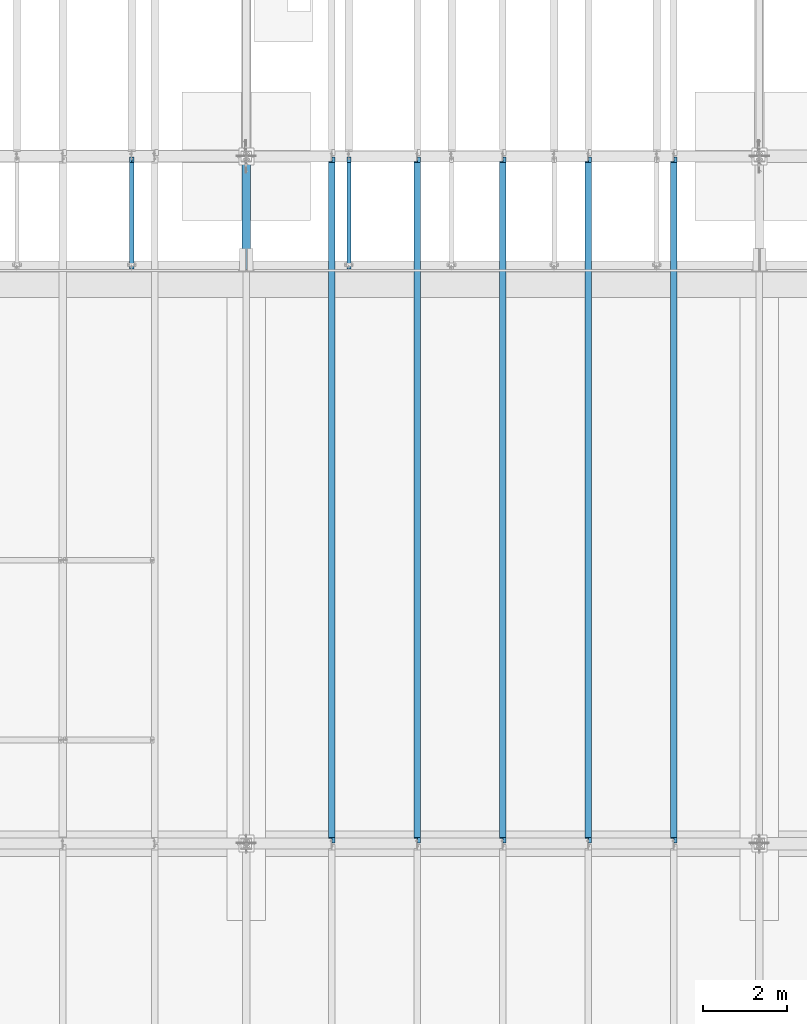
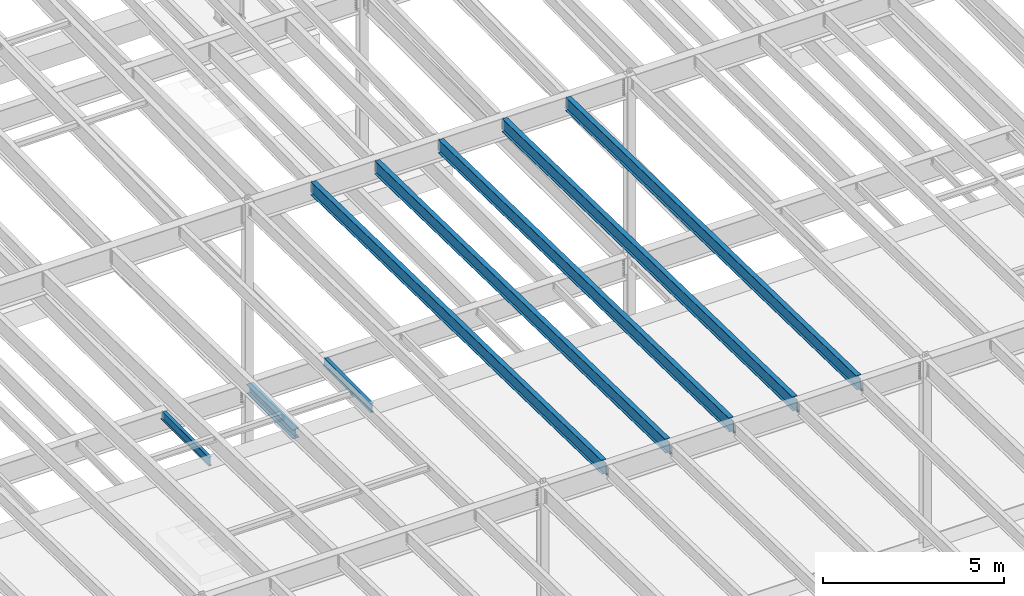
# One storey, part 1100 of 1763: 8 beams, 8 elements without a shape of their own.
"""IFC2X3 building model written with IfcOpenShell, lengths in millimetres."""

from ifc_helpers import new_model, si_unit, frame, origin_with_axes, place, context, subcontext, project, spatial, faceted_brep, material, type_object, element, aggregate, save


model = new_model("IFC2X3")

# Units and contexts
model_context = context("Model", 3, precision=1e-05, world=origin_with_axes())
body_context = subcontext(model_context, "Body", "Model", "MODEL_VIEW")
ifc_project = project(units=[si_unit("LENGTHUNIT", "METRE", prefix="MILLI"), si_unit("AREAUNIT", "SQUARE_METRE"), si_unit("VOLUMEUNIT", "CUBIC_METRE"), si_unit("MASSUNIT", "GRAM", prefix="KILO"), si_unit("TIMEUNIT", "SECOND"), si_unit("PLANEANGLEUNIT", "RADIAN"), si_unit("SOLIDANGLEUNIT", "STERADIAN"), si_unit("THERMODYNAMICTEMPERATUREUNIT", "DEGREE_CELSIUS"), si_unit("LUMINOUSINTENSITYUNIT", "LUMEN")], contexts=[model_context])

# Site, building, storey
site_placement = place(None, origin_with_axes())
site = spatial("IfcSite", under=ifc_project, at=site_placement, CompositionType="ELEMENT")
building_placement = place(site_placement, origin_with_axes())
building = spatial("IfcBuilding", under=site, at=building_placement, Name="Undefined", CompositionType="ELEMENT")
storey_placement = place(building_placement, origin_with_axes())
storey = spatial("IfcBuildingStorey", under=building, at=storey_placement, Name="Undefined", CompositionType="ELEMENT", Elevation=0.0)

# Assembly, beam
assembly_1_placement = place(storey_placement, origin_with_axes())
assembly_1 = element("IfcElementAssembly", 1, at=assembly_1_placement, inside=storey, Name="BEAM", AssemblyPlace="NOTDEFINED", PredefinedType="RIGID_FRAME")
ifc_material = material(Name="STEEL/A992")
beam_type_1 = type_object("IfcBeamType", Name="W12X16", PredefinedType="NOTDEFINED")
beam_1_placement = place(assembly_1_placement, frame((-59156.0372736983, 27279.6, 5041.9), z_axis=(0.0, 0.0, 1.0), x_axis=(0.0, 1.0, 0.0)))
beam_1 = element("IfcBeam", 2, at=beam_1_placement, type_object=beam_type_1, material=ifc_material, Name="BEAM", ObjectType="W12X16", context=body_context, shape_type="Brep", body=[
    faceted_brep([(63.5000000000036, -3.17499999999927, -146.05), (63.5000000000036, -50.7999999999993, -146.05), (2724.15000000001, -50.7999999999993, -146.05), (2724.15000000001, -3.17499999999927, -146.05), (63.5000000000036, -50.7999999999993, -152.4), (2724.15000000001, -50.7999999999993, -152.4), (63.5000000000036, 50.7999999999993, -152.4), (2724.15000000001, 50.7999999999993, -152.4), (63.5000000000036, 50.7999999999993, -146.05), (63.5000000000036, 3.17499999999927, -146.05), (2724.15000000001, 3.17499999999927, -146.05), (2724.15000000001, 50.7999999999993, -146.05), (2724.15000000001, 3.17499999999927, 120.390001678466), (2724.15000000001, -3.17499999999927, 120.390001678466), (63.5000000000036, -3.17499999999927, 146.05), (63.5000000000036, -50.7999999999993, 146.05), (63.5000000000036, -50.7999999999993, 152.4), (63.5000000000036, 50.7999999999993, 152.4), (63.5000000000036, 50.7999999999993, 146.05), (63.5000000000036, 3.17499999999927, 146.05), (2597.15000000001, 50.7999999999993, 146.05), (2597.15000000001, 3.17499999999927, 146.05), (2597.15000000001, 3.17499999999927, 133.090001487731), (2598.11672992259, 3.17499999999927, 128.229921969685), (2600.86974382307, 3.17499999999927, 124.109745501532), (2604.98992029122, 3.17499999999927, 121.356731601053), (2609.84999980927, 3.17499999999927, 120.390001678466), (2598.11672992259, -3.17499999999927, 128.229921969685), (2597.15000000001, -3.17499999999927, 133.090001487731), (2600.86974382307, -3.17499999999927, 124.109745501532), (2604.98992029122, -3.17499999999927, 121.356731601053), (2609.84999980927, -3.17499999999927, 120.390001678466), (2597.15000000001, -3.17499999999927, 146.05), (2597.15000000001, -50.7999999999993, 146.05), (2597.15000000001, -50.7999999999993, 152.4), (2597.15000000001, 50.7999999999993, 152.4)], [[[0, 1, 2, 3]], [[1, 4, 5, 2]], [[4, 6, 7, 5]], [[8, 9, 10, 11]], [[3, 2, 5, 7, 11, 10, 12, 13]], [[6, 8, 11, 7]], [[4, 1, 0, 14, 15, 16, 17, 18, 19, 9, 8, 6]], [[19, 18, 20, 21]], [[10, 9, 19, 21, 22, 23, 24, 25, 26, 12]], [[27, 23, 22, 28]], [[29, 24, 23, 27]], [[30, 25, 24, 29]], [[31, 26, 25, 30]], [[13, 12, 26, 31]], [[30, 29, 27, 28, 32, 14, 0, 3, 13, 31]], [[15, 14, 32, 33]], [[16, 15, 33, 34]], [[17, 16, 34, 35]], [[18, 17, 35, 20]], [[34, 33, 32, 28, 22, 21, 20, 35]]]),
])
aggregate(assembly_1, [beam_1])

assembly_2_placement = place(storey_placement, origin_with_axes())
assembly_2 = element("IfcElementAssembly", 3, at=assembly_2_placement, inside=storey, Name="BEAM", AssemblyPlace="NOTDEFINED", PredefinedType="RIGID_FRAME")
beam_2_placement = place(assembly_2_placement, frame((-64318.5872736984, 27279.6, 5041.9), z_axis=(0.0, 0.0, 1.0), x_axis=(0.0, 1.0, 0.0)))
beam_2 = element("IfcBeam", 4, at=beam_2_placement, type_object=beam_type_1, material=ifc_material, Name="BEAM", ObjectType="W12X16", context=body_context, shape_type="Brep", body=[
    faceted_brep([(63.5000000000036, -3.17499999999927, -146.05), (63.5000000000036, -50.7999999999993, -146.05), (2724.15000000001, -50.7999999999993, -146.05), (2724.15000000001, -3.17499999999927, -146.05), (63.5000000000036, -50.7999999999993, -152.4), (2724.15000000001, -50.7999999999993, -152.4), (63.5000000000036, 50.7999999999993, -152.4), (2724.15000000001, 50.7999999999993, -152.4), (63.5000000000036, 50.7999999999993, -146.05), (63.5000000000036, 3.17499999999927, -146.05), (2724.15000000001, 3.17499999999927, -146.05), (2724.15000000001, 50.7999999999993, -146.05), (2724.15000000001, 3.17499999999927, 120.390001678466), (2724.15000000001, -3.17499999999927, 120.390001678466), (63.5000000000036, -3.17499999999927, 146.05), (63.5000000000036, -50.7999999999993, 146.05), (63.5000000000036, -50.7999999999993, 152.4), (63.5000000000036, 50.7999999999993, 152.4), (63.5000000000036, 50.7999999999993, 146.05), (63.5000000000036, 3.17499999999927, 146.05), (2597.15000000001, 50.7999999999993, 146.05), (2597.15000000001, 3.17499999999927, 146.05), (2597.15000000001, 3.17499999999927, 133.090001487731), (2598.11672992259, 3.17499999999927, 128.229921969685), (2600.86974382307, 3.17499999999927, 124.109745501532), (2604.98992029122, 3.17499999999927, 121.356731601053), (2609.84999980927, 3.17499999999927, 120.390001678466), (2598.11672992259, -3.17499999999927, 128.229921969685), (2597.15000000001, -3.17499999999927, 133.090001487731), (2600.86974382307, -3.17499999999927, 124.109745501532), (2604.98992029122, -3.17499999999927, 121.356731601053), (2609.84999980927, -3.17499999999927, 120.390001678466), (2597.15000000001, -3.17499999999927, 146.05), (2597.15000000001, -50.7999999999993, 146.05), (2597.15000000001, -50.7999999999993, 152.4), (2597.15000000001, 50.7999999999993, 152.4)], [[[0, 1, 2, 3]], [[1, 4, 5, 2]], [[4, 6, 7, 5]], [[8, 9, 10, 11]], [[3, 2, 5, 7, 11, 10, 12, 13]], [[6, 8, 11, 7]], [[4, 1, 0, 14, 15, 16, 17, 18, 19, 9, 8, 6]], [[19, 18, 20, 21]], [[10, 9, 19, 21, 22, 23, 24, 25, 26, 12]], [[27, 23, 22, 28]], [[29, 24, 23, 27]], [[30, 25, 24, 29]], [[31, 26, 25, 30]], [[13, 12, 26, 31]], [[30, 29, 27, 28, 32, 14, 0, 3, 13, 31]], [[15, 14, 32, 33]], [[16, 15, 33, 34]], [[17, 16, 34, 35]], [[18, 17, 35, 20]], [[34, 33, 32, 28, 22, 21, 20, 35]]]),
])
aggregate(assembly_2, [beam_2])

assembly_3_placement = place(storey_placement, origin_with_axes())
assembly_3 = element("IfcElementAssembly", 5, at=assembly_3_placement, inside=storey, Name="BEAM", AssemblyPlace="NOTDEFINED", PredefinedType="RIGID_FRAME")
beam_type_2 = type_object("IfcBeamType", Name="W18X40", PredefinedType="NOTDEFINED")
beam_3_placement = place(assembly_3_placement, frame((-51434.4372736983, 13685.8551306872, 11404.7768219843), z_axis=(0.0, 0.0209013539966291, 0.999781542838788), x_axis=(0.0, 0.999781542776098, -0.0209013569953182)))
beam_3 = element("IfcBeam", 6, at=beam_3_placement, type_object=beam_type_2, material=ifc_material, Name="BEAM", ObjectType="W18X40", context=body_context, shape_type="Brep", body=[
    faceted_brep([(131.750078376836, 4.26866853544198, -214.312499999891), (131.750078376825, 4.26882839153404, -227.012499999888), (28.545974688046, 4.26881528460945, -227.012499999948), (28.2804694526694, 4.26865539480787, -214.312499999951), (131.750069241622, 76.1999999999971, -214.312499999891), (131.750069241631, 76.1999999999971, -227.012499999888), (150.800068605527, -3.96875, 195.002501487816), (150.800068605527, 3.96875, 195.002501487816), (149.833338682944, 3.96875, 190.142421969771), (149.833338682944, -3.96875, 190.142421969771), (147.080324782468, 3.96875, 186.022245501617), (147.080324782468, -3.96875, 186.022245501617), (142.96014831432, 3.96875, 183.26923160114), (142.96014831432, -3.96875, 183.26923160114), (138.100068796275, 3.96875, 182.30250167855), (138.100068796275, -3.96875, 182.30250167855), (19.9888663522943, 3.96875, 182.30250167848), (19.9888663522943, -3.96875, 182.30250167848), (28.2804694526694, -3.96875, -214.312499999951), (16325.9408112312, -3.96875, -214.312499990356), (16317.649208128, -3.96875, 182.302501822607), (16200.8104101848, -3.96875, 182.302501822538), (16195.9503306668, -3.96875, 183.269231745124), (16191.8301541986, -3.96875, 186.022245645598), (16189.0771402981, -3.96875, 190.142422113749), (16188.1104103755, -3.96875, 195.00250163179), (16188.1104103755, -3.96875, 214.312500009501), (150.800068605517, -3.96875, 214.312500000058), (28.2804694526694, -76.1999999999971, -214.312499999951), (16325.9408112312, -76.1999999999971, -214.312499990356), (28.545974688046, -76.1999999999971, -227.012499999948), (16326.2063164666, -76.1999999999971, -227.012499990355), (16224.3506317604, 76.1999999999971, -215.844166655699), (16224.3506317604, 4.71875000000728, -215.844166655699), (16226.2104072906, 4.71875000000728, -215.805286329723), (16226.2104011431, 76.1999999999971, -215.805286458244), (16224.3186108535, 4.71875000000728, -214.312499990414), (16224.3186108535, 76.1999999999971, -214.312499990414), (16226.2104072906, 4.71875000000728, -214.312499990414), (16226.2104073293, 4.26882837418816, -214.312499990414), (16226.2104073293, 4.26866852503008, -227.012499990411), (16226.2104011431, 76.1999999999971, -227.012499990411), (16326.2063164666, 4.26867712486273, -227.012499990355), (16325.9408112312, 4.26883695115976, -214.312499990356), (16325.9408112312, 3.96875, -214.312499990356), (16317.649208128, 3.96875, 182.302501822607), (16200.8104101848, 3.96875, 182.302501822538), (16195.9503306668, 3.96875, 183.269231745124), (16191.8301541986, 3.96875, 186.022245645598), (16189.0771402981, 3.96875, 190.142422113749), (16188.1104103755, 3.96875, 195.00250163179), (16188.1104103755, -76.1999999999971, 227.012500009499), (16188.1104103755, -76.1999999999971, 214.312500009501), (16188.1104103755, 3.96875, 214.312500009501), (16188.1104103755, 76.1999999999971, 214.312500009501), (16188.1104103755, 76.1999999999971, 227.012500009499), (150.800068605517, 3.96875, 214.312500000058), (150.800068605517, 76.1999999999971, 214.312500000058), (150.800068605509, 76.1999999999971, 227.012500000057), (150.800068605509, -76.1999999999971, 227.012500000057), (150.800068605517, -76.1999999999971, 214.312500000058), (28.2804694526694, 3.96875, -214.312499999951)], [[[0, 1, 2, 3]], [[4, 5, 1, 0]], [[6, 7, 8, 9]], [[9, 8, 10, 11]], [[11, 10, 12, 13]], [[13, 12, 14, 15]], [[15, 14, 16, 17]], [[9, 11, 13, 15, 17, 18, 19, 20, 21, 22, 23, 24, 25, 26, 27, 6]], [[18, 28, 29, 19]], [[28, 30, 31, 29]], [[32, 33, 34, 35]], [[36, 33, 32, 37]], [[33, 36, 38, 34]], [[39, 40, 41, 35, 34, 38]], [[42, 40, 39, 43]], [[44, 45, 20, 19, 29, 31, 42, 43]], [[20, 45, 46, 21]], [[21, 46, 47, 22]], [[22, 47, 48, 23]], [[23, 48, 49, 24]], [[24, 49, 50, 25]], [[51, 52, 26, 25, 50, 53, 54, 55]], [[54, 53, 56, 57]], [[55, 54, 57, 58]], [[51, 55, 58, 59]], [[52, 51, 59, 60]], [[26, 52, 60, 27]], [[59, 58, 57, 56, 7, 6, 27, 60]], [[53, 50, 49, 48, 47, 46, 45, 44, 61, 16, 14, 12, 10, 8, 7, 56]], [[30, 28, 18, 17, 16, 61, 3, 2]], [[41, 40, 42, 31, 30, 2, 1, 5]], [[37, 32, 35, 41, 5, 4]], [[61, 44, 43, 39, 38, 36, 37, 4, 0, 3]]]),
])
aggregate(assembly_3, [beam_3])

assembly_4_placement = place(storey_placement, origin_with_axes())
assembly_4 = element("IfcElementAssembly", 7, at=assembly_4_placement, inside=storey, Name="BEAM", AssemblyPlace="NOTDEFINED", PredefinedType="RIGID_FRAME")
beam_4_placement = place(assembly_4_placement, frame((-53466.4372736983, 13685.8551306872, 11404.7768219843), z_axis=(0.0, 0.0209013539966291, 0.999781542838788), x_axis=(0.0, 0.999781542776098, -0.0209013569953182)))
beam_4 = element("IfcBeam", 8, at=beam_4_placement, type_object=beam_type_2, material=ifc_material, Name="BEAM", ObjectType="W18X40", context=body_context, shape_type="Brep", body=[
    faceted_brep([(131.750078376836, 4.26866853544198, -214.312499999891), (131.750078376825, 4.26882839153404, -227.012499999888), (28.545974688046, 4.26881528460945, -227.012499999948), (28.2804694526694, 4.26865539480787, -214.312499999951), (131.750069241622, 76.1999999999971, -214.312499999891), (131.750069241631, 76.1999999999971, -227.012499999888), (150.800068605527, -3.96875, 195.002501487816), (150.800068605527, 3.96875, 195.002501487816), (149.833338682944, 3.96875, 190.142421969771), (149.833338682944, -3.96875, 190.142421969771), (147.080324782468, 3.96875, 186.022245501617), (147.080324782468, -3.96875, 186.022245501617), (142.96014831432, 3.96875, 183.26923160114), (142.96014831432, -3.96875, 183.26923160114), (138.100068796275, 3.96875, 182.30250167855), (138.100068796275, -3.96875, 182.30250167855), (19.9888663522943, 3.96875, 182.30250167848), (19.9888663522943, -3.96875, 182.30250167848), (28.2804694526694, -3.96875, -214.312499999951), (16325.9408112312, -3.96875, -214.312499990356), (16317.649208128, -3.96875, 182.302501822607), (16200.8104101848, -3.96875, 182.302501822538), (16195.9503306668, -3.96875, 183.269231745124), (16191.8301541986, -3.96875, 186.022245645598), (16189.0771402981, -3.96875, 190.142422113749), (16188.1104103755, -3.96875, 195.00250163179), (16188.1104103755, -3.96875, 214.312500009501), (150.800068605517, -3.96875, 214.312500000058), (28.2804694526694, -76.1999999999971, -214.312499999951), (16325.9408112312, -76.1999999999971, -214.312499990356), (28.545974688046, -76.1999999999971, -227.012499999948), (16326.2063164666, -76.1999999999971, -227.012499990355), (16224.3506317604, 76.1999999999971, -215.844166655699), (16224.3506317604, 4.71875000000728, -215.844166655699), (16226.2104072906, 4.71875000000728, -215.805286329723), (16226.2104011431, 76.1999999999971, -215.805286458244), (16224.3186108535, 4.71875000000728, -214.312499990414), (16224.3186108535, 76.1999999999971, -214.312499990414), (16226.2104072906, 4.71875000000728, -214.312499990414), (16226.2104073293, 4.26882837418816, -214.312499990414), (16226.2104073293, 4.26866852503008, -227.012499990411), (16226.2104011431, 76.1999999999971, -227.012499990411), (16326.2063164666, 4.26867712486273, -227.012499990355), (16325.9408112312, 4.26883695115976, -214.312499990356), (16325.9408112312, 3.96875, -214.312499990356), (16317.649208128, 3.96875, 182.302501822607), (16200.8104101848, 3.96875, 182.302501822538), (16195.9503306668, 3.96875, 183.269231745124), (16191.8301541986, 3.96875, 186.022245645598), (16189.0771402981, 3.96875, 190.142422113749), (16188.1104103755, 3.96875, 195.00250163179), (16188.1104103755, -76.1999999999971, 227.012500009499), (16188.1104103755, -76.1999999999971, 214.312500009501), (16188.1104103755, 3.96875, 214.312500009501), (16188.1104103755, 76.1999999999971, 214.312500009501), (16188.1104103755, 76.1999999999971, 227.012500009499), (150.800068605517, 3.96875, 214.312500000058), (150.800068605517, 76.1999999999971, 214.312500000058), (150.800068605509, 76.1999999999971, 227.012500000057), (150.800068605509, -76.1999999999971, 227.012500000057), (150.800068605517, -76.1999999999971, 214.312500000058), (28.2804694526694, 3.96875, -214.312499999951)], [[[0, 1, 2, 3]], [[4, 5, 1, 0]], [[6, 7, 8, 9]], [[9, 8, 10, 11]], [[11, 10, 12, 13]], [[13, 12, 14, 15]], [[15, 14, 16, 17]], [[9, 11, 13, 15, 17, 18, 19, 20, 21, 22, 23, 24, 25, 26, 27, 6]], [[18, 28, 29, 19]], [[28, 30, 31, 29]], [[32, 33, 34, 35]], [[36, 33, 32, 37]], [[33, 36, 38, 34]], [[39, 40, 41, 35, 34, 38]], [[42, 40, 39, 43]], [[44, 45, 20, 19, 29, 31, 42, 43]], [[20, 45, 46, 21]], [[21, 46, 47, 22]], [[22, 47, 48, 23]], [[23, 48, 49, 24]], [[24, 49, 50, 25]], [[51, 52, 26, 25, 50, 53, 54, 55]], [[54, 53, 56, 57]], [[55, 54, 57, 58]], [[51, 55, 58, 59]], [[52, 51, 59, 60]], [[26, 52, 60, 27]], [[59, 58, 57, 56, 7, 6, 27, 60]], [[53, 50, 49, 48, 47, 46, 45, 44, 61, 16, 14, 12, 10, 8, 7, 56]], [[30, 28, 18, 17, 16, 61, 3, 2]], [[41, 40, 42, 31, 30, 2, 1, 5]], [[37, 32, 35, 41, 5, 4]], [[61, 44, 43, 39, 38, 36, 37, 4, 0, 3]]]),
])
aggregate(assembly_4, [beam_4])

assembly_5_placement = place(storey_placement, origin_with_axes())
assembly_5 = element("IfcElementAssembly", 9, at=assembly_5_placement, inside=storey, Name="BEAM", AssemblyPlace="NOTDEFINED", PredefinedType="RIGID_FRAME")
beam_5_placement = place(assembly_5_placement, frame((-55498.4372736983, 13685.8551306872, 11404.7768219843), z_axis=(0.0, 0.0209013539966291, 0.999781542838788), x_axis=(0.0, 0.999781542776098, -0.0209013569953182)))
beam_5 = element("IfcBeam", 10, at=beam_5_placement, type_object=beam_type_2, material=ifc_material, Name="BEAM", ObjectType="W18X40", context=body_context, shape_type="Brep", body=[
    faceted_brep([(131.750078376836, 4.26866853544198, -214.312499999891), (131.750078376825, 4.26882839153404, -227.012499999888), (28.545974688046, 4.26881528460945, -227.012499999948), (28.2804694526694, 4.26865539480787, -214.312499999951), (131.750069241622, 76.1999999999971, -214.312499999891), (131.750069241631, 76.1999999999971, -227.012499999888), (150.800068605527, -3.96875, 195.002501487816), (150.800068605527, 3.96875, 195.002501487816), (149.833338682944, 3.96875, 190.142421969771), (149.833338682944, -3.96875, 190.142421969771), (147.080324782468, 3.96875, 186.022245501617), (147.080324782468, -3.96875, 186.022245501617), (142.96014831432, 3.96875, 183.26923160114), (142.96014831432, -3.96875, 183.26923160114), (138.100068796275, 3.96875, 182.30250167855), (138.100068796275, -3.96875, 182.30250167855), (19.9888663522943, 3.96875, 182.30250167848), (19.9888663522943, -3.96875, 182.30250167848), (28.2804694526694, -3.96875, -214.312499999951), (16325.9408112312, -3.96875, -214.312499990356), (16317.649208128, -3.96875, 182.302501822607), (16200.8104101848, -3.96875, 182.302501822538), (16195.9503306668, -3.96875, 183.269231745124), (16191.8301541986, -3.96875, 186.022245645598), (16189.0771402981, -3.96875, 190.142422113749), (16188.1104103755, -3.96875, 195.00250163179), (16188.1104103755, -3.96875, 214.312500009501), (150.800068605517, -3.96875, 214.312500000058), (28.2804694526694, -76.1999999999971, -214.312499999951), (16325.9408112312, -76.1999999999971, -214.312499990356), (28.545974688046, -76.1999999999971, -227.012499999948), (16326.2063164666, -76.1999999999971, -227.012499990355), (16224.3506317604, 76.1999999999971, -215.844166655699), (16224.3506317604, 4.71875000000728, -215.844166655699), (16226.2104072906, 4.71875000000728, -215.805286329723), (16226.2104011431, 76.1999999999971, -215.805286458244), (16224.3186108535, 4.71875000000728, -214.312499990414), (16224.3186108535, 76.1999999999971, -214.312499990414), (16226.2104072906, 4.71875000000728, -214.312499990414), (16226.2104073293, 4.26882837418816, -214.312499990414), (16226.2104073293, 4.26866852503008, -227.012499990411), (16226.2104011431, 76.1999999999971, -227.012499990411), (16326.2063164666, 4.26867712486273, -227.012499990355), (16325.9408112312, 4.26883695115976, -214.312499990356), (16325.9408112312, 3.96875, -214.312499990356), (16317.649208128, 3.96875, 182.302501822607), (16200.8104101848, 3.96875, 182.302501822538), (16195.9503306668, 3.96875, 183.269231745124), (16191.8301541986, 3.96875, 186.022245645598), (16189.0771402981, 3.96875, 190.142422113749), (16188.1104103755, 3.96875, 195.00250163179), (16188.1104103755, -76.1999999999971, 227.012500009499), (16188.1104103755, -76.1999999999971, 214.312500009501), (16188.1104103755, 3.96875, 214.312500009501), (16188.1104103755, 76.1999999999971, 214.312500009501), (16188.1104103755, 76.1999999999971, 227.012500009499), (150.800068605517, 3.96875, 214.312500000058), (150.800068605517, 76.1999999999971, 214.312500000058), (150.800068605509, 76.1999999999971, 227.012500000057), (150.800068605509, -76.1999999999971, 227.012500000057), (150.800068605517, -76.1999999999971, 214.312500000058), (28.2804694526694, 3.96875, -214.312499999951)], [[[0, 1, 2, 3]], [[4, 5, 1, 0]], [[6, 7, 8, 9]], [[9, 8, 10, 11]], [[11, 10, 12, 13]], [[13, 12, 14, 15]], [[15, 14, 16, 17]], [[9, 11, 13, 15, 17, 18, 19, 20, 21, 22, 23, 24, 25, 26, 27, 6]], [[18, 28, 29, 19]], [[28, 30, 31, 29]], [[32, 33, 34, 35]], [[36, 33, 32, 37]], [[33, 36, 38, 34]], [[39, 40, 41, 35, 34, 38]], [[42, 40, 39, 43]], [[44, 45, 20, 19, 29, 31, 42, 43]], [[20, 45, 46, 21]], [[21, 46, 47, 22]], [[22, 47, 48, 23]], [[23, 48, 49, 24]], [[24, 49, 50, 25]], [[51, 52, 26, 25, 50, 53, 54, 55]], [[54, 53, 56, 57]], [[55, 54, 57, 58]], [[51, 55, 58, 59]], [[52, 51, 59, 60]], [[26, 52, 60, 27]], [[59, 58, 57, 56, 7, 6, 27, 60]], [[53, 50, 49, 48, 47, 46, 45, 44, 61, 16, 14, 12, 10, 8, 7, 56]], [[30, 28, 18, 17, 16, 61, 3, 2]], [[41, 40, 42, 31, 30, 2, 1, 5]], [[37, 32, 35, 41, 5, 4]], [[61, 44, 43, 39, 38, 36, 37, 4, 0, 3]]]),
])
aggregate(assembly_5, [beam_5])

assembly_6_placement = place(storey_placement, origin_with_axes())
assembly_6 = element("IfcElementAssembly", 11, at=assembly_6_placement, inside=storey, Name="BEAM", AssemblyPlace="NOTDEFINED", PredefinedType="RIGID_FRAME")
beam_6_placement = place(assembly_6_placement, frame((-57530.4372736983, 13685.8551306872, 11404.7768219843), z_axis=(0.0, 0.0209013539966291, 0.999781542838788), x_axis=(0.0, 0.999781542776098, -0.0209013569953182)))
beam_6 = element("IfcBeam", 12, at=beam_6_placement, type_object=beam_type_2, material=ifc_material, Name="BEAM", ObjectType="W18X40", context=body_context, shape_type="Brep", body=[
    faceted_brep([(131.750078376836, 4.26866853544198, -214.312499999891), (131.750078376825, 4.26882839153404, -227.012499999888), (28.545974688046, 4.26881528460945, -227.012499999948), (28.2804694526694, 4.26865539480787, -214.312499999951), (131.750069241622, 76.1999999999971, -214.312499999891), (131.750069241631, 76.1999999999971, -227.012499999888), (150.800068605527, -3.96875, 195.002501487816), (150.800068605527, 3.96875, 195.002501487816), (149.833338682944, 3.96875, 190.142421969771), (149.833338682944, -3.96875, 190.142421969771), (147.080324782468, 3.96875, 186.022245501617), (147.080324782468, -3.96875, 186.022245501617), (142.96014831432, 3.96875, 183.26923160114), (142.96014831432, -3.96875, 183.26923160114), (138.100068796275, 3.96875, 182.30250167855), (138.100068796275, -3.96875, 182.30250167855), (19.9888663522943, 3.96875, 182.30250167848), (19.9888663522943, -3.96875, 182.30250167848), (28.2804694526694, -3.96875, -214.312499999951), (16325.9408112312, -3.96875, -214.312499990356), (16317.649208128, -3.96875, 182.302501822607), (16200.8104101848, -3.96875, 182.302501822538), (16195.9503306668, -3.96875, 183.269231745124), (16191.8301541986, -3.96875, 186.022245645598), (16189.0771402981, -3.96875, 190.142422113749), (16188.1104103755, -3.96875, 195.00250163179), (16188.1104103755, -3.96875, 214.312500009501), (150.800068605517, -3.96875, 214.312500000058), (28.2804694526694, -76.1999999999971, -214.312499999951), (16325.9408112312, -76.1999999999971, -214.312499990356), (28.545974688046, -76.1999999999971, -227.012499999948), (16326.2063164666, -76.1999999999971, -227.012499990355), (16224.3506317604, 76.1999999999971, -215.844166655699), (16224.3506317604, 4.71875000000728, -215.844166655699), (16226.2104072906, 4.71875000000728, -215.805286329723), (16226.2104011431, 76.1999999999971, -215.805286458244), (16224.3186108535, 4.71875000000728, -214.312499990414), (16224.3186108535, 76.1999999999971, -214.312499990414), (16226.2104072906, 4.71875000000728, -214.312499990414), (16226.2104073293, 4.26882837418816, -214.312499990414), (16226.2104073293, 4.26866852503008, -227.012499990411), (16226.2104011431, 76.1999999999971, -227.012499990411), (16326.2063164666, 4.26867712486273, -227.012499990355), (16325.9408112312, 4.26883695115976, -214.312499990356), (16325.9408112312, 3.96875, -214.312499990356), (16317.649208128, 3.96875, 182.302501822607), (16200.8104101848, 3.96875, 182.302501822538), (16195.9503306668, 3.96875, 183.269231745124), (16191.8301541986, 3.96875, 186.022245645598), (16189.0771402981, 3.96875, 190.142422113749), (16188.1104103755, 3.96875, 195.00250163179), (16188.1104103755, -76.1999999999971, 227.012500009499), (16188.1104103755, -76.1999999999971, 214.312500009501), (16188.1104103755, 3.96875, 214.312500009501), (16188.1104103755, 76.1999999999971, 214.312500009501), (16188.1104103755, 76.1999999999971, 227.012500009499), (150.800068605517, 3.96875, 214.312500000058), (150.800068605517, 76.1999999999971, 214.312500000058), (150.800068605509, 76.1999999999971, 227.012500000057), (150.800068605509, -76.1999999999971, 227.012500000057), (150.800068605517, -76.1999999999971, 214.312500000058), (28.2804694526694, 3.96875, -214.312499999951)], [[[0, 1, 2, 3]], [[4, 5, 1, 0]], [[6, 7, 8, 9]], [[9, 8, 10, 11]], [[11, 10, 12, 13]], [[13, 12, 14, 15]], [[15, 14, 16, 17]], [[9, 11, 13, 15, 17, 18, 19, 20, 21, 22, 23, 24, 25, 26, 27, 6]], [[18, 28, 29, 19]], [[28, 30, 31, 29]], [[32, 33, 34, 35]], [[36, 33, 32, 37]], [[33, 36, 38, 34]], [[39, 40, 41, 35, 34, 38]], [[42, 40, 39, 43]], [[44, 45, 20, 19, 29, 31, 42, 43]], [[20, 45, 46, 21]], [[21, 46, 47, 22]], [[22, 47, 48, 23]], [[23, 48, 49, 24]], [[24, 49, 50, 25]], [[51, 52, 26, 25, 50, 53, 54, 55]], [[54, 53, 56, 57]], [[55, 54, 57, 58]], [[51, 55, 58, 59]], [[52, 51, 59, 60]], [[26, 52, 60, 27]], [[59, 58, 57, 56, 7, 6, 27, 60]], [[53, 50, 49, 48, 47, 46, 45, 44, 61, 16, 14, 12, 10, 8, 7, 56]], [[30, 28, 18, 17, 16, 61, 3, 2]], [[41, 40, 42, 31, 30, 2, 1, 5]], [[37, 32, 35, 41, 5, 4]], [[61, 44, 43, 39, 38, 36, 37, 4, 0, 3]]]),
])
aggregate(assembly_6, [beam_6])

assembly_7_placement = place(storey_placement, origin_with_axes())
assembly_7 = element("IfcElementAssembly", 13, at=assembly_7_placement, inside=storey, Name="BEAM", AssemblyPlace="NOTDEFINED", PredefinedType="RIGID_FRAME")
beam_7_placement = place(assembly_7_placement, frame((-59562.4372736983, 13685.8551306872, 11404.7768219843), z_axis=(0.0, 0.0209013539966291, 0.999781542838788), x_axis=(0.0, 0.999781542776098, -0.0209013569953182)))
beam_7 = element("IfcBeam", 14, at=beam_7_placement, type_object=beam_type_2, material=ifc_material, Name="BEAM", ObjectType="W18X40", context=body_context, shape_type="Brep", body=[
    faceted_brep([(131.750078376836, 4.26866853544198, -214.312499999891), (131.750078376825, 4.26882839153404, -227.012499999888), (28.545974688046, 4.26881528460945, -227.012499999948), (28.2804694526694, 4.26865539480787, -214.312499999951), (131.750069241622, 76.1999999999971, -214.312499999891), (131.750069241631, 76.1999999999971, -227.012499999888), (150.800068605527, -3.96875, 195.002501487816), (150.800068605527, 3.96875, 195.002501487816), (149.833338682944, 3.96875, 190.142421969771), (149.833338682944, -3.96875, 190.142421969771), (147.080324782468, 3.96875, 186.022245501617), (147.080324782468, -3.96875, 186.022245501617), (142.96014831432, 3.96875, 183.26923160114), (142.96014831432, -3.96875, 183.26923160114), (138.100068796275, 3.96875, 182.30250167855), (138.100068796275, -3.96875, 182.30250167855), (19.9888663522943, 3.96875, 182.30250167848), (19.9888663522943, -3.96875, 182.30250167848), (28.2804694526694, -3.96875, -214.312499999951), (16325.9408112312, -3.96875, -214.312499990356), (16317.649208128, -3.96875, 182.302501822607), (16200.8104101848, -3.96875, 182.302501822538), (16195.9503306668, -3.96875, 183.269231745124), (16191.8301541986, -3.96875, 186.022245645598), (16189.0771402981, -3.96875, 190.142422113749), (16188.1104103755, -3.96875, 195.00250163179), (16188.1104103755, -3.96875, 214.312500009501), (150.800068605517, -3.96875, 214.312500000058), (28.2804694526694, -76.1999999999971, -214.312499999951), (16325.9408112312, -76.1999999999971, -214.312499990356), (28.545974688046, -76.1999999999971, -227.012499999948), (16326.2063164666, -76.1999999999971, -227.012499990355), (16224.3506317604, 76.1999999999971, -215.844166655699), (16224.3506317604, 4.71875000000728, -215.844166655699), (16226.2104072906, 4.71875000000728, -215.805286329723), (16226.2104011431, 76.1999999999971, -215.805286458244), (16224.3186108535, 4.71875000000728, -214.312499990414), (16224.3186108535, 76.1999999999971, -214.312499990414), (16226.2104072906, 4.71875000000728, -214.312499990414), (16226.2104073293, 4.26882837418816, -214.312499990414), (16226.2104073293, 4.26866852503008, -227.012499990411), (16226.2104011431, 76.1999999999971, -227.012499990411), (16326.2063164666, 4.26867712486273, -227.012499990355), (16325.9408112312, 4.26883695115976, -214.312499990356), (16325.9408112312, 3.96875, -214.312499990356), (16317.649208128, 3.96875, 182.302501822607), (16200.8104101848, 3.96875, 182.302501822538), (16195.9503306668, 3.96875, 183.269231745124), (16191.8301541986, 3.96875, 186.022245645598), (16189.0771402981, 3.96875, 190.142422113749), (16188.1104103755, 3.96875, 195.00250163179), (16188.1104103755, -76.1999999999971, 227.012500009499), (16188.1104103755, -76.1999999999971, 214.312500009501), (16188.1104103755, 3.96875, 214.312500009501), (16188.1104103755, 76.1999999999971, 214.312500009501), (16188.1104103755, 76.1999999999971, 227.012500009499), (150.800068605517, 3.96875, 214.312500000058), (150.800068605517, 76.1999999999971, 214.312500000058), (150.800068605509, 76.1999999999971, 227.012500000057), (150.800068605509, -76.1999999999971, 227.012500000057), (150.800068605517, -76.1999999999971, 214.312500000058), (28.2804694526694, 3.96875, -214.312499999951)], [[[0, 1, 2, 3]], [[4, 5, 1, 0]], [[6, 7, 8, 9]], [[9, 8, 10, 11]], [[11, 10, 12, 13]], [[13, 12, 14, 15]], [[15, 14, 16, 17]], [[9, 11, 13, 15, 17, 18, 19, 20, 21, 22, 23, 24, 25, 26, 27, 6]], [[18, 28, 29, 19]], [[28, 30, 31, 29]], [[32, 33, 34, 35]], [[36, 33, 32, 37]], [[33, 36, 38, 34]], [[39, 40, 41, 35, 34, 38]], [[42, 40, 39, 43]], [[44, 45, 20, 19, 29, 31, 42, 43]], [[20, 45, 46, 21]], [[21, 46, 47, 22]], [[22, 47, 48, 23]], [[23, 48, 49, 24]], [[24, 49, 50, 25]], [[51, 52, 26, 25, 50, 53, 54, 55]], [[54, 53, 56, 57]], [[55, 54, 57, 58]], [[51, 55, 58, 59]], [[52, 51, 59, 60]], [[26, 52, 60, 27]], [[59, 58, 57, 56, 7, 6, 27, 60]], [[53, 50, 49, 48, 47, 46, 45, 44, 61, 16, 14, 12, 10, 8, 7, 56]], [[30, 28, 18, 17, 16, 61, 3, 2]], [[41, 40, 42, 31, 30, 2, 1, 5]], [[37, 32, 35, 41, 5, 4]], [[61, 44, 43, 39, 38, 36, 37, 4, 0, 3]]]),
])
aggregate(assembly_7, [beam_7])

assembly_8_placement = place(storey_placement, origin_with_axes())
assembly_8 = element("IfcElementAssembly", 15, at=assembly_8_placement, inside=storey, Name="BEAM", AssemblyPlace="NOTDEFINED", PredefinedType="RIGID_FRAME")
beam_type_3 = type_object("IfcBeamType", Name="W12X50", PredefinedType="NOTDEFINED")
beam_8_placement = place(assembly_8_placement, frame((-61594.4372736983, 27279.6, 5038.725), z_axis=(0.0, 0.0, 1.0), x_axis=(0.0, 1.0, 0.0)))
beam_8 = element("IfcBeam", 16, at=beam_8_placement, type_object=beam_type_3, material=ifc_material, Name="BEAM", ObjectType="W12X50", context=body_context, shape_type="Brep", body=[
    faceted_brep([(50.7999999999993, -103.1875, -139.7), (50.7999999999993, -103.1875, -155.575), (2598.7375, -103.1875, -155.575), (2598.7375, -103.1875, -139.7), (50.7999999999993, -4.76250000000073, -139.7), (2598.7375, -4.76249999999709, -139.7), (50.7999999999993, -4.76250000000073, 139.7), (2598.7375, -4.76249999999709, 139.7), (50.7999999999993, -103.1875, 139.7), (2598.7375, -103.1875, 139.7), (50.7999999999993, -103.1875, 155.575), (2598.7375, -103.1875, 155.575), (50.7999999999993, 103.1875, 155.575), (2598.7375, 103.1875, 155.575), (50.7999999999993, 103.1875, 139.7), (2598.7375, 103.1875, 139.7), (50.7999999999993, 4.76250000000073, 139.7), (2598.7375, 4.76249999999709, 139.7), (50.7999999999993, 4.76250000000073, -139.7), (2598.7375, 4.76249999999709, -139.7), (50.7999999999993, 103.1875, -139.7), (2598.7375, 103.1875, -139.7), (50.7999999999993, 103.1875, -155.575), (2598.7375, 103.1875, -155.575)], [[[0, 1, 2, 3]], [[4, 0, 3, 5]], [[6, 4, 5, 7]], [[8, 6, 7, 9]], [[10, 8, 9, 11]], [[12, 10, 11, 13]], [[14, 12, 13, 15]], [[16, 14, 15, 17]], [[18, 16, 17, 19]], [[20, 18, 19, 21]], [[1, 0, 4, 6, 8, 10, 12, 14, 16, 18, 20, 22]], [[1, 22, 23, 2]], [[19, 17, 15, 13, 11, 9, 7, 5, 3, 2, 23, 21]], [[22, 20, 21, 23]]]),
])
aggregate(assembly_8, [beam_8])

save(model, "model.ifc")
